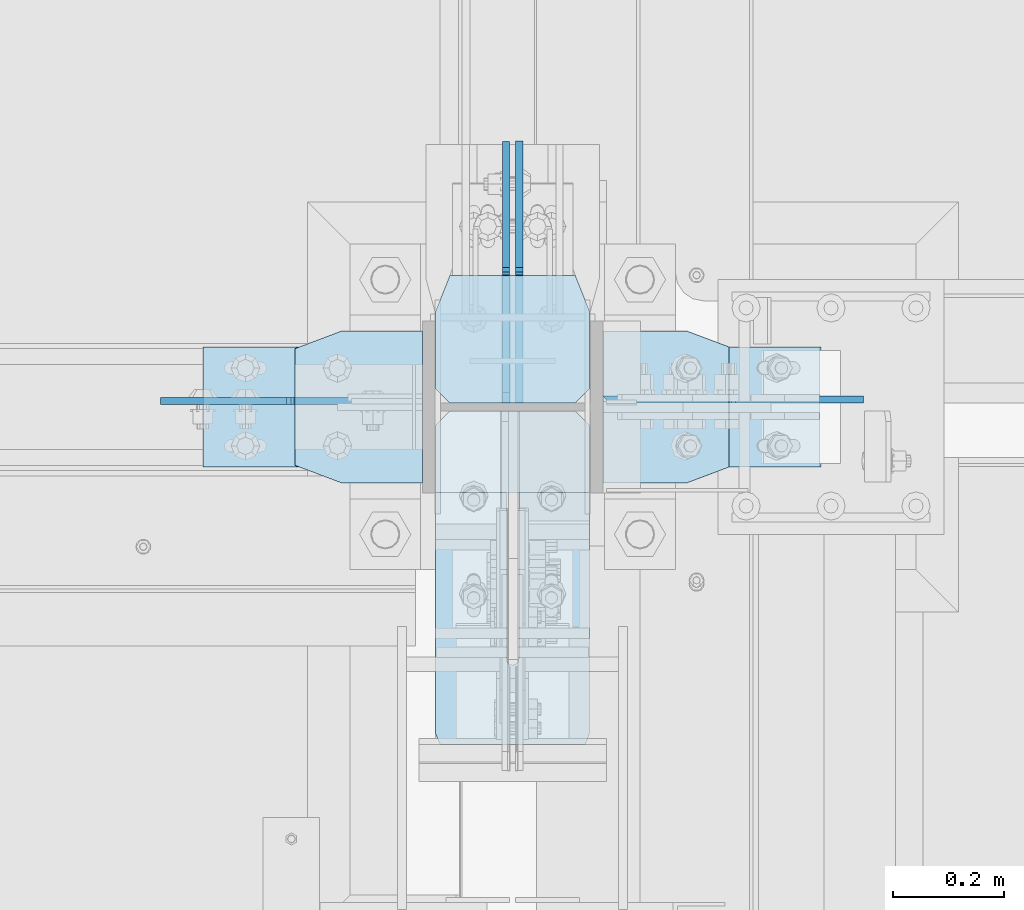
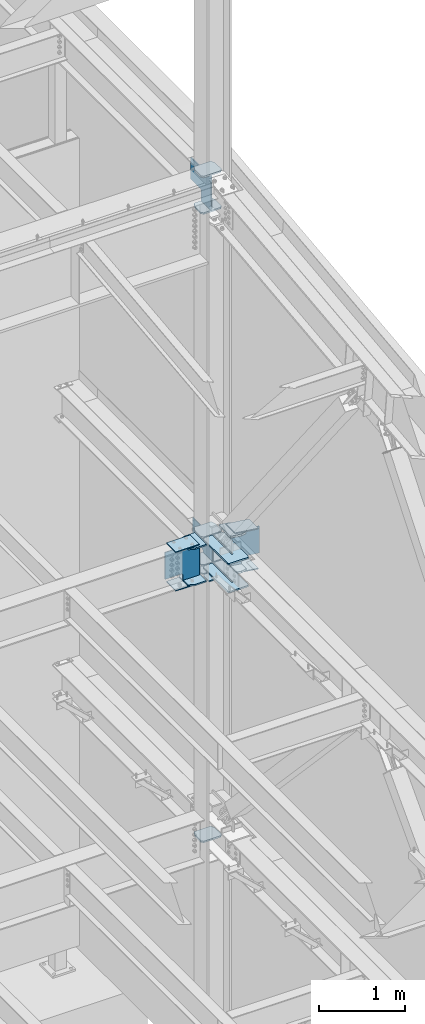
# One storey, part 1091 of 1179: 21 plates, 1 element without a shape of its own.
"""IFC2X3 building model written with IfcOpenShell, lengths in millimetres."""

from ifc_helpers import new_model, si_unit, frame, origin_with_axes, place, context, subcontext, project, spatial, faceted_brep, material, type_object, element, aggregate, save


model = new_model("IFC2X3")

# Units and contexts
model_context = context("Model", 3, precision=1e-05, world=origin_with_axes())
body_context = subcontext(model_context, "Body", "Model", "MODEL_VIEW")
ifc_project = project(units=[si_unit("LENGTHUNIT", "METRE", prefix="MILLI"), si_unit("AREAUNIT", "SQUARE_METRE"), si_unit("VOLUMEUNIT", "CUBIC_METRE"), si_unit("MASSUNIT", "GRAM", prefix="KILO"), si_unit("TIMEUNIT", "SECOND"), si_unit("PLANEANGLEUNIT", "RADIAN"), si_unit("SOLIDANGLEUNIT", "STERADIAN"), si_unit("THERMODYNAMICTEMPERATUREUNIT", "DEGREE_CELSIUS"), si_unit("LUMINOUSINTENSITYUNIT", "LUMEN")], contexts=[model_context])

# Site, building, storey
site_placement = place(None, origin_with_axes())
site = spatial("IfcSite", under=ifc_project, at=site_placement, CompositionType="ELEMENT")
building_placement = place(site_placement, origin_with_axes())
building = spatial("IfcBuilding", under=site, at=building_placement, Name="Undefined", CompositionType="ELEMENT")
storey_placement = place(building_placement, origin_with_axes())
storey = spatial("IfcBuildingStorey", under=building, at=storey_placement, Name="Undefined", CompositionType="ELEMENT", Elevation=0.0)

# Assembly, plates
assembly_placement = place(storey_placement, origin_with_axes())
assembly = element("IfcElementAssembly", 1, at=assembly_placement, inside=storey, Name="COLUMN", AssemblyPlace="NOTDEFINED", PredefinedType="RIGID_FRAME")
ifc_material = material(Name="STEEL/A572-GR.50")
plate_type_1 = type_object("IfcPlateType", PredefinedType="NOTDEFINED")
plate_1_placement = place(assembly_placement, frame((24169.6874938965, 33785.7911790881, 7605.7125), z_axis=(0.0, 1.0, 0.0), x_axis=(1.0, 0.0, 0.0)))
plate_1 = element("IfcPlate", 2, at=plate_1_placement, type_object=plate_type_1, material=ifc_material, Name="PLATE", context=body_context, shape_type="Brep", body=[
    faceted_brep([(127.000006103513, -11.1125000000002, 598.665070911848), (127.000006103513, -11.1125000000002, 153.987500190735), (127.000006103513, 11.1125000000002, 153.987500190735), (127.000006103513, 11.1125000000002, 598.665070911848), (127.845894812999, -11.1125000000002, 149.734930475584), (127.845894812999, 11.1125000000002, 149.734930475584), (130.254782053442, -11.1125000000002, 146.129775949928), (130.254782053442, 11.1125000000002, 146.129775949928), (133.859936579101, -11.1125000000002, 143.720888709489), (133.859936579101, 11.1125000000002, 143.720888709489), (138.112505912784, -11.1125000000002, 142.875), (138.112505912784, 11.1125000000002, 142.875), (142.365075627931, -11.1125000000002, 143.720888709489), (142.365075627931, 11.1125000000002, 143.720888709489), (145.970230153591, -11.1125000000002, 146.129775949928), (145.970230153591, 11.1125000000002, 146.129775949928), (148.379117394034, -11.1125000000002, 149.734930475584), (148.379117394034, 11.1125000000002, 149.734930475584), (149.225006103519, -11.1125000000002, 153.987500190735), (149.225006103519, 11.1125000000002, 153.987500190735), (149.225006103519, -11.1125000000002, 598.665070911848), (149.225006103519, 11.1125000000002, 598.665070911848), (0.0, -11.1125000000002, 573.265071293317), (25.3999996185303, -11.1125000000002, 598.665070911848), (25.3999996185303, 11.1125000000002, 598.665070911848), (0.0, 11.1125000000002, 573.265071293317), (0.0, -11.1125000000002, 19.0499992370605), (0.0, 11.1125000000002, 19.0499992370605), (7.9375, -11.1125000000002, 0.0), (7.9375, 11.1125000000002, 0.0), (268.287506103516, -11.1125000000002, 0.0), (268.287506103516, 11.1125000000002, 0.0), (276.225006103516, -11.1125000000002, 19.0499992370605), (276.225006103516, 11.1125000000002, 19.0499992370605), (276.225006103516, -11.1125000000002, 573.265071293317), (276.225006103516, 11.1125000000002, 573.265071293317), (250.825006484985, -11.1125000000002, 598.665070911848), (250.825006484985, 11.1125000000002, 598.665070911848)], [[[0, 1, 2, 3]], [[4, 5, 2, 1]], [[6, 7, 5, 4]], [[8, 9, 7, 6]], [[10, 11, 9, 8]], [[12, 13, 11, 10]], [[14, 15, 13, 12]], [[16, 17, 15, 14]], [[18, 19, 17, 16]], [[20, 21, 19, 18]], [[22, 23, 24, 25]], [[26, 22, 25, 27]], [[28, 26, 27, 29]], [[30, 28, 29, 31]], [[32, 30, 31, 33]], [[34, 32, 33, 35]], [[36, 34, 35, 37]], [[16, 14, 12, 10, 8, 6, 4, 1, 0, 23, 22, 26, 28, 30, 32, 34, 36, 20, 18]], [[24, 23, 0, 3]], [[37, 35, 33, 31, 29, 27, 25, 24, 3, 2, 5, 7, 9, 11, 13, 15, 17, 19, 21]], [[36, 37, 21, 20]]]),
])
plate_2_placement = place(assembly_placement, frame((24169.6874938965, 33785.7911790881, 8002.5875), z_axis=(0.0, 1.0, 0.0), x_axis=(1.0, 0.0, 0.0)))
plate_2 = element("IfcPlate", 3, at=plate_2_placement, type_object=plate_type_1, material=ifc_material, Name="PLATE", context=body_context, shape_type="Brep", body=[
    faceted_brep([(127.000006103513, -11.1125000000002, 598.665070911848), (127.000006103513, -11.1125000000002, 153.987500190735), (127.000006103513, 11.1125000000002, 153.987500190735), (127.000006103513, 11.1125000000002, 598.665070911848), (127.845894812999, -11.1125000000002, 149.734930475584), (127.845894812999, 11.1125000000002, 149.734930475584), (130.254782053442, -11.1125000000002, 146.129775949928), (130.254782053442, 11.1125000000002, 146.129775949928), (133.859936579101, -11.1125000000002, 143.720888709489), (133.859936579101, 11.1125000000002, 143.720888709489), (138.112505912784, -11.1125000000002, 142.875), (138.112505912784, 11.1125000000002, 142.875), (142.365075627931, -11.1125000000002, 143.720888709489), (142.365075627931, 11.1125000000002, 143.720888709489), (145.970230153591, -11.1125000000002, 146.129775949928), (145.970230153591, 11.1125000000002, 146.129775949928), (148.379117394034, -11.1125000000002, 149.734930475584), (148.379117394034, 11.1125000000002, 149.734930475584), (149.225006103519, -11.1125000000002, 153.987500190735), (149.225006103519, 11.1125000000002, 153.987500190735), (149.225006103519, -11.1125000000002, 598.665070911848), (149.225006103519, 11.1125000000002, 598.665070911848), (0.0, -11.1125000000002, 573.265071293317), (25.3999996185303, -11.1125000000002, 598.665070911848), (25.3999996185303, 11.1125000000002, 598.665070911848), (0.0, 11.1125000000002, 573.265071293317), (0.0, -11.1125000000002, 19.0499992370605), (0.0, 11.1125000000002, 19.0499992370605), (7.9375, -11.1125000000002, 0.0), (7.9375, 11.1125000000002, 0.0), (268.287506103516, -11.1125000000002, 0.0), (268.287506103516, 11.1125000000002, 0.0), (276.225006103516, -11.1125000000002, 19.0499992370605), (276.225006103516, 11.1125000000002, 19.0499992370605), (276.225006103516, -11.1125000000002, 573.265071293317), (276.225006103516, 11.1125000000002, 573.265071293317), (250.825006484985, -11.1125000000002, 598.665070911848), (250.825006484985, 11.1125000000002, 598.665070911848)], [[[0, 1, 2, 3]], [[4, 5, 2, 1]], [[6, 7, 5, 4]], [[8, 9, 7, 6]], [[10, 11, 9, 8]], [[12, 13, 11, 10]], [[14, 15, 13, 12]], [[16, 17, 15, 14]], [[18, 19, 17, 16]], [[20, 21, 19, 18]], [[22, 23, 24, 25]], [[26, 22, 25, 27]], [[28, 26, 27, 29]], [[30, 28, 29, 31]], [[32, 30, 31, 33]], [[34, 32, 33, 35]], [[36, 34, 35, 37]], [[16, 14, 12, 10, 8, 6, 4, 1, 0, 23, 22, 26, 28, 30, 32, 34, 36, 20, 18]], [[24, 23, 0, 3]], [[37, 35, 33, 31, 29, 27, 25, 24, 3, 2, 5, 7, 9, 11, 13, 15, 17, 19, 21]], [[36, 37, 21, 20]]]),
])
plate_type_2 = type_object("IfcPlateType", PredefinedType="NOTDEFINED")
plate_3_placement = place(assembly_placement, frame((23917.2752770017, 34528.125, 7489.82500080334), z_axis=(0.0, -1.0, 0.0), x_axis=(1.0, 0.0, 0.0)))
plate_3 = element("IfcPlate", 4, at=plate_3_placement, type_object=plate_type_2, material=ifc_material, Name="PLATE", context=body_context, shape_type="Brep", body=[
    faceted_brep([(0.0, -9.52499999999964, 31.75), (-1.45519152283669e-11, -9.52499999999964, 241.299987792969), (1.81898940354586e-11, 9.52499999999964, 241.299987792969), (0.0, 9.52499999999964, 31.75), (84.1374969482276, -9.52499999999691, 273.049987792969), (84.1374969482604, 9.52500000000327, 273.049987792969), (228.599999999984, -9.52499999999054, 273.049987792969), (228.600000000017, 9.52500000000964, 273.049987792969), (228.599999999984, -9.52499999999054, 0.0), (228.600000000017, 9.52500000000964, 0.0), (84.1374969482276, -9.52499999999691, 0.0), (84.1374969482604, 9.52500000000327, 0.0)], [[[0, 1, 2, 3]], [[1, 4, 5, 2]], [[4, 6, 7, 5]], [[6, 8, 9, 7]], [[8, 10, 11, 9]], [[10, 0, 3, 11]], [[5, 7, 9, 11, 3, 2]], [[10, 8, 6, 4, 1, 0]]]),
])
plate_4_placement = place(assembly_placement, frame((23917.2752770017, 34528.125, 8004.17499919666), z_axis=(0.0, -1.0, 0.0), x_axis=(1.0, 0.0, 0.0)))
plate_4 = element("IfcPlate", 5, at=plate_4_placement, type_object=plate_type_2, material=ifc_material, Name="PLATE", context=body_context, shape_type="Brep", body=[
    faceted_brep([(0.0, -9.52499999999964, 31.75), (-1.45519152283669e-11, -9.52499999999964, 241.299987792969), (1.81898940354586e-11, 9.52499999999964, 241.299987792969), (0.0, 9.52499999999964, 31.75), (84.1374969482276, -9.52499999999691, 273.049987792969), (84.1374969482604, 9.52500000000327, 273.049987792969), (228.599999999984, -9.52499999999054, 273.049987792969), (228.600000000017, 9.52500000000964, 273.049987792969), (228.599999999984, -9.52499999999054, 0.0), (228.600000000017, 9.52500000000964, 0.0), (84.1374969482276, -9.52499999999691, 0.0), (84.1374969482604, 9.52500000000327, 0.0)], [[[0, 1, 2, 3]], [[1, 4, 5, 2]], [[4, 6, 7, 5]], [[6, 8, 9, 7]], [[8, 10, 11, 9]], [[10, 0, 3, 11]], [[5, 7, 9, 11, 3, 2]], [[10, 8, 6, 4, 1, 0]]]),
])
plate_type_3 = type_object("IfcPlateType", PredefinedType="NOTDEFINED")
plate_5_placement = place(assembly_placement, frame((24445.9125, 34627.34375, 12590.4625), z_axis=(-1.0, 0.0, 0.0), x_axis=(0.0, -1.0, 0.0)))
plate_5 = element("IfcPlate", 6, at=plate_5_placement, type_object=plate_type_3, material=ifc_material, Name="PLATE", context=body_context, shape_type="Brep", body=[
    faceted_brep([(0.0, -11.1125000000002, 25.3999996185303), (0.0, -11.1124999999993, 250.825000381468), (0.0, 11.1124999999993, 250.825000381468), (0.0, 11.1125000000002, 25.3999996185303), (63.5, -11.1124999999993, 276.224999999999), (63.5, 11.1124999999993, 276.224999999999), (203.200000381468, -11.1124999999993, 276.224999999999), (203.200000381468, 11.1124999999993, 276.224999999999), (228.599999999999, -11.1125000000002, 250.824999618533), (228.599999999999, 11.1125000000002, 250.824999618533), (228.599999999999, -11.1124999999993, 25.3999996185303), (228.599999999999, 11.1124999999993, 25.3999996185303), (203.200000381468, -11.1124999999993, 0.0), (203.200000381468, 11.1124999999993, 0.0), (63.5, -11.1125000000002, 0.0), (63.5, 11.1125000000002, 0.0)], [[[0, 1, 2, 3]], [[1, 4, 5, 2]], [[4, 6, 7, 5]], [[6, 8, 9, 7]], [[8, 10, 11, 9]], [[10, 12, 13, 11]], [[12, 14, 15, 13]], [[14, 0, 3, 15]], [[5, 7, 9, 11, 13, 15, 3, 2]], [[14, 12, 10, 8, 6, 4, 1, 0]]]),
])
plate_6_placement = place(assembly_placement, frame((24445.9125, 34627.34375, 13107.9875), z_axis=(-1.0, 0.0, 0.0), x_axis=(0.0, -1.0, 0.0)))
plate_6 = element("IfcPlate", 7, at=plate_6_placement, type_object=plate_type_3, material=ifc_material, Name="PLATE", context=body_context, shape_type="Brep", body=[
    faceted_brep([(0.0, -11.1125000000002, 25.3999996185303), (0.0, -11.1124999999993, 250.825000381468), (0.0, 11.1124999999993, 250.825000381468), (0.0, 11.1125000000002, 25.3999996185303), (63.5, -11.1124999999993, 276.224999999999), (63.5, 11.1124999999993, 276.224999999999), (203.200000381468, -11.1124999999993, 276.224999999999), (203.200000381468, 11.1124999999993, 276.224999999999), (228.599999999999, -11.1125000000002, 250.824999618533), (228.599999999999, 11.1125000000002, 250.824999618533), (228.599999999999, -11.1124999999993, 25.3999996185303), (228.599999999999, 11.1124999999993, 25.3999996185303), (203.200000381468, -11.1124999999993, 0.0), (203.200000381468, 11.1124999999993, 0.0), (63.5, -11.1125000000002, 0.0), (63.5, 11.1125000000002, 0.0)], [[[0, 1, 2, 3]], [[1, 4, 5, 2]], [[4, 6, 7, 5]], [[6, 8, 9, 7]], [[8, 10, 11, 9]], [[10, 12, 13, 11]], [[12, 14, 15, 13]], [[14, 0, 3, 15]], [[5, 7, 9, 11, 13, 15, 3, 2]], [[14, 12, 10, 8, 6, 4, 1, 0]]]),
])
plate_7_placement = place(assembly_placement, frame((24445.9125, 34627.34375, 7608.8875), z_axis=(-1.0, 0.0, 0.0), x_axis=(0.0, -1.0, 0.0)))
plate_7 = element("IfcPlate", 8, at=plate_7_placement, type_object=plate_type_3, material=ifc_material, Name="PLATE", context=body_context, shape_type="Brep", body=[
    faceted_brep([(0.0, -11.1124999999993, 250.825000381468), (63.5, -11.1124999999993, 276.224999999999), (63.5, 11.1124999999993, 276.224999999999), (0.0, 11.1124999999993, 250.825000381468), (63.5, -11.1125000000002, 0.0), (0.0, -11.1125000000002, 25.3999996185303), (0.0, 11.1125000000002, 25.3999996185303), (63.5, 11.1125000000002, 0.0), (203.200000381468, -11.1124999999993, 276.224999999999), (203.200000381468, 11.1124999999993, 276.224999999999), (228.599999999999, -11.1125000000002, 250.824999618533), (228.599999999999, 11.1125000000002, 250.824999618533), (228.599999999999, -11.1124999999993, 25.3999996185303), (228.599999999999, 11.1124999999993, 25.3999996185303), (203.200000381468, -11.1124999999993, 0.0), (203.200000381468, 11.1124999999993, 0.0)], [[[0, 1, 2, 3]], [[4, 5, 6, 7]], [[5, 0, 3, 6]], [[1, 8, 9, 2]], [[8, 10, 11, 9]], [[10, 12, 13, 11]], [[12, 14, 15, 13]], [[14, 4, 7, 15]], [[2, 9, 11, 13, 15, 7, 6, 3]], [[4, 14, 12, 10, 8, 1, 0, 5]]]),
])
plate_8_placement = place(assembly_placement, frame((24445.9125, 34627.34375, 8002.5875), z_axis=(-1.0, 0.0, 0.0), x_axis=(0.0, -1.0, 0.0)))
plate_8 = element("IfcPlate", 9, at=plate_8_placement, type_object=plate_type_3, material=ifc_material, Name="PLATE", context=body_context, shape_type="Brep", body=[
    faceted_brep([(0.0, -11.1124999999993, 250.825000381468), (63.5, -11.1124999999993, 276.224999999999), (63.5, 11.1124999999993, 276.224999999999), (0.0, 11.1124999999993, 250.825000381468), (63.5, -11.1125000000002, 0.0), (0.0, -11.1125000000002, 25.3999996185303), (0.0, 11.1125000000002, 25.3999996185303), (63.5, 11.1125000000002, 0.0), (203.200000381468, -11.1124999999993, 276.224999999999), (203.200000381468, 11.1124999999993, 276.224999999999), (228.599999999999, -11.1125000000002, 250.824999618533), (228.599999999999, 11.1125000000002, 250.824999618533), (228.599999999999, -11.1124999999993, 25.3999996185303), (228.599999999999, 11.1124999999993, 25.3999996185303), (203.200000381468, -11.1124999999993, 0.0), (203.200000381468, 11.1124999999993, 0.0)], [[[0, 1, 2, 3]], [[4, 5, 6, 7]], [[5, 0, 3, 6]], [[1, 8, 9, 2]], [[8, 10, 11, 9]], [[10, 12, 13, 11]], [[12, 14, 15, 13]], [[14, 4, 7, 15]], [[2, 9, 11, 13, 15, 7, 6, 3]], [[4, 14, 12, 10, 8, 1, 0, 5]]]),
])
plate_9_placement = place(assembly_placement, frame((24445.9125, 34627.34375, 3694.1125), z_axis=(-1.0, 0.0, 0.0), x_axis=(0.0, -1.0, 0.0)))
plate_9 = element("IfcPlate", 10, at=plate_9_placement, type_object=plate_type_3, material=ifc_material, Name="PLATE", context=body_context, shape_type="Brep", body=[
    faceted_brep([(63.5, -11.1125000000002, 0.0), (0.0, -11.1125000000002, 25.3999996185303), (0.0, 11.1125000000002, 25.3999996185303), (63.5, 11.1125000000002, 0.0), (0.0, -11.1124999999993, 250.825000381468), (63.5, -11.1124999999993, 276.224999999999), (63.5, 11.1124999999993, 276.224999999999), (0.0, 11.1124999999993, 250.825000381468), (203.200000381468, -11.1124999999993, 276.224999999999), (203.200000381468, 11.1124999999993, 276.224999999999), (228.599999999999, -11.1125000000002, 250.824999618533), (228.599999999999, 11.1125000000002, 250.824999618533), (228.599999999999, -11.1124999999993, 25.3999996185303), (228.599999999999, 11.1124999999993, 25.3999996185303), (203.200000381468, -11.1124999999993, 0.0), (203.200000381468, 11.1124999999993, 0.0)], [[[0, 1, 2, 3]], [[4, 5, 6, 7]], [[1, 4, 7, 2]], [[5, 8, 9, 6]], [[8, 10, 11, 9]], [[10, 12, 13, 11]], [[12, 14, 15, 13]], [[14, 0, 3, 15]], [[6, 9, 11, 13, 15, 3, 2, 7]], [[0, 14, 12, 10, 8, 5, 4, 1]]]),
])
plate_type_4 = type_object("IfcPlateType", PredefinedType="NOTDEFINED")
plate_10_placement = place(assembly_placement, frame((24295.89375, 34398.7437499185, 12620.625), z_axis=(0.0, 0.707106781186542, 0.707106781186553), x_axis=(0.0, 0.707106781186553, -0.707106781186542)))
plate_10 = element("IfcPlate", 11, at=plate_10_placement, type_object=plate_type_4, material=ifc_material, Name="PLATE", context=body_context, shape_type="Brep", body=[
    faceted_brep([(0.0, -6.34999999999854, 0.0), (-323.289220358607, -6.35000000000002, 323.289220358594), (-323.289220358607, 6.35000000000002, 323.289220358594), (0.0, 6.34999999999854, 0.0), (-323.289220358678, -6.35000000000002, 350.229988721738), (-323.289220358678, 6.35000000000002, 350.229988721738), (-175.676260369275, -6.34999999999854, 497.842948711121), (-175.676260369275, 6.34999999999854, 497.842948711121), (-173.431196069267, -6.34999999999854, 495.597884411116), (-173.431196069267, 6.34999999999854, 495.597884411116), (-165.190843132961, -6.34999999999854, 490.091856610146), (-165.190843132961, 6.34999999999854, 490.091856610146), (-155.470684096883, -6.34999999999854, 488.158396764957), (-155.470684096883, 6.34999999999854, 488.158396764957), (-145.750525060801, -6.34999999999854, 490.091856610125), (-145.750525060801, 6.34999999999854, 490.091856610125), (-137.510172124514, -6.34999999999854, 495.597884411058), (-137.510172124514, 6.34999999999854, 495.597884411058), (15.1541822026338, -6.34999999999854, 648.2622387382), (15.1541822026338, 6.34999999999854, 648.2622387382), (230.680329108358, -6.34999999999854, 432.736091832448), (230.680329108358, 6.34999999999854, 432.736091832448), (78.015974781214, -6.34999999999854, 280.071737505328), (78.015974781214, 6.34999999999854, 280.071737505328), (72.5099469802699, -6.34999999999854, 271.831384569035), (72.5099469802699, 6.34999999999854, 271.831384569035), (70.5764871351112, -6.34999999999854, 262.111225532957), (70.5764871351112, 6.34999999999854, 262.111225532957), (72.509946980299, -6.34999999999854, 252.391066496879), (72.509946980299, 6.34999999999854, 252.391066496879), (78.015974781254, -6.34999999999854, 244.150713560572), (78.015974781254, 6.34999999999854, 244.150713560572), (174.553728352508, -6.34999999999854, 147.612959989299), (174.553728352508, 6.34999999999854, 147.612959989299), (26.9407683631471, -6.34999999999854, -6.91215973347425e-11), (26.9407683631471, 6.34999999999854, -6.91215973347425e-11)], [[[0, 1, 2, 3]], [[1, 4, 5, 2]], [[4, 6, 7, 5]], [[6, 8, 9, 7]], [[8, 10, 11, 9]], [[10, 12, 13, 11]], [[12, 14, 15, 13]], [[14, 16, 17, 15]], [[16, 18, 19, 17]], [[18, 20, 21, 19]], [[20, 22, 23, 21]], [[22, 24, 25, 23]], [[24, 26, 27, 25]], [[26, 28, 29, 27]], [[28, 30, 31, 29]], [[30, 32, 33, 31]], [[32, 34, 35, 33]], [[34, 0, 3, 35]], [[5, 7, 9, 11, 13, 15, 17, 19, 21, 23, 25, 27, 29, 31, 33, 35, 3, 2]], [[34, 32, 30, 28, 26, 24, 22, 20, 18, 16, 14, 12, 10, 8, 6, 4, 1, 0]]]),
])
plate_11_placement = place(assembly_placement, frame((24145.875, 34402.7125, 7994.65), z_axis=(-1.0, 0.0, 0.0), x_axis=(0.0, 0.0, -1.0)))
plate_11 = element("IfcPlate", 12, at=plate_11_placement, type_object=plate_type_4, material=ifc_material, Name="PLATE", context=body_context, shape_type="Brep", body=[
    faceted_brep([(495.3, 6.34999999999854, 12.7000000000007), (495.3, -6.34999999999854, 0.0), (0.0, -6.34999999999854, 0.0), (0.0, 6.35000000000036, 12.6999999999571), (400.049987793925, -6.34999999999854, 469.900000816429), (400.049987074385, -6.34999999999854, 253.999723479657), (400.049987074385, 6.34999999999854, 253.999723479657), (400.049987793925, 6.34999999999854, 469.900000816429), (401.983446895269, -6.34999999999854, 244.27956441756), (401.983446895269, 6.34999999999854, 244.27956441756), (407.489474690605, -6.34999999999854, 236.03921145252), (407.489474690605, 6.34999999999854, 236.03921145252), (415.729827637304, -6.34999999999854, 230.533183629737), (415.729827637304, 6.34999999999854, 230.533183629737), (425.449986692962, -6.34999999999854, 228.599723776479), (425.449986692962, 6.34999999999854, 228.599723776479), (495.299999196217, -6.34999999999854, 228.599723776602), (495.3, 6.34999999999854, 228.599723776602), (19.0500000066177, -6.34999999999854, 469.900000816731), (19.0500000066177, 6.34999999999854, 469.900000816429), (19.0500000014745, 6.34999999999854, 253.999723394838), (19.0500000014745, -6.34999999999854, 253.999723394838), (17.1165401561248, 6.34999999999854, 244.279564358931), (17.1165401561248, -6.34999999999854, 244.279564358931), (11.610512355127, 6.34999999999854, 236.039211422831), (11.610512355127, -6.34999999999854, 236.039211422831), (3.3701594188924, 6.34999999999854, 230.533183622028), (3.3701594188924, -6.34999999999854, 230.533183622028), (0.0, 6.34999999999854, 229.862817233581), (0.0, -6.34999999999854, 229.862817233581), (0.0, -6.34999999999854, 228.599723776912), (0.0, 6.34999999999854, 228.599723776912)], [[[0, 1, 2, 3]], [[4, 5, 6, 7]], [[8, 9, 6, 5]], [[10, 11, 9, 8]], [[12, 13, 11, 10]], [[14, 15, 13, 12]], [[16, 17, 15, 14]], [[18, 19, 20, 21]], [[21, 20, 22, 23]], [[23, 22, 24, 25]], [[25, 24, 26, 27]], [[27, 26, 28, 29]], [[30, 29, 28, 31, 3, 2]], [[23, 25, 27, 29, 30, 2, 1, 16, 14, 12, 10, 8, 5, 4, 18, 21]], [[4, 7, 19, 18]], [[31, 28, 26, 24, 22, 20, 19, 7, 6, 9, 11, 13, 15, 17, 0, 3]], [[17, 16, 1, 0]]]),
])
plate_type_5 = type_object("IfcPlateType", PredefinedType="NOTDEFINED")
plate_12_placement = place(assembly_placement, frame((23752.1750017409, 34499.5499969482, 7473.95000087879), z_axis=(0.0, -1.0, 0.0), x_axis=(1.0, 0.0, 0.0)))
plate_12 = element("IfcPlate", 13, at=plate_12_placement, type_object=plate_type_5, material=ifc_material, Name="PLATE", context=body_context, shape_type="Brep", body=[
    faceted_brep([(0.0, -6.34999999999854, 0.0), (0.0, -6.350000000004, 215.899993896484), (0.0, 6.35000000000582, 215.899993896484), (0.0, 6.34999999999854, 0.0), (317.499999999996, -6.35000000014134, 215.899993896484), (317.5, 6.34999999985939, 215.899993896484), (317.499999999996, -6.35000000014134, 0.0), (317.5, 6.34999999985939, 0.0)], [[[0, 1, 2, 3]], [[1, 4, 5, 2]], [[4, 6, 7, 5]], [[6, 0, 3, 7]], [[5, 7, 3, 2]], [[6, 4, 1, 0]]]),
])
plate_13_placement = place(assembly_placement, frame((23752.1750017409, 34499.5499969482, 8020.04999912121), z_axis=(0.0, -1.0, 0.0), x_axis=(1.0, 0.0, 0.0)))
plate_13 = element("IfcPlate", 14, at=plate_13_placement, type_object=plate_type_5, material=ifc_material, Name="PLATE", context=body_context, shape_type="Brep", body=[
    faceted_brep([(0.0, -6.34999999999854, 0.0), (0.0, -6.350000000004, 215.899993896484), (0.0, 6.35000000000582, 215.899993896484), (0.0, 6.34999999999854, 0.0), (317.499999999996, -6.35000000014134, 215.899993896484), (317.5, 6.34999999985939, 215.899993896484), (317.499999999996, -6.35000000014134, 0.0), (317.5, 6.34999999985939, 0.0)], [[[0, 1, 2, 3]], [[1, 4, 5, 2]], [[4, 6, 7, 5]], [[6, 0, 3, 7]], [[5, 7, 3, 2]], [[6, 4, 1, 0]]]),
])
plate_14_placement = place(assembly_placement, frame((24859.0345724513, 34283.6500030518, 7401.53692644335), z_axis=(0.0, 1.0, 0.0), x_axis=(-0.99100656978554, 0.0, 0.133813222971043)))
plate_14 = element("IfcPlate", 15, at=plate_14_placement, type_object=plate_type_5, material=ifc_material, Name="PLATE", context=body_context, shape_type="Brep", body=[
    faceted_brep([(0.0, -6.34999999999854, 0.0), (0.0, -6.350000000004, 215.899993896484), (0.0, 6.35000000000582, 215.899993896484), (0.0, 6.34999999999854, 0.0), (317.499999999996, -6.35000000014134, 215.899993896484), (317.5, 6.34999999985939, 215.899993896484), (317.499999999996, -6.35000000014134, 0.0), (317.5, 6.34999999985939, 0.0)], [[[0, 1, 2, 3]], [[1, 4, 5, 2]], [[4, 6, 7, 5]], [[6, 0, 3, 7]], [[5, 7, 3, 2]], [[6, 4, 1, 0]]]),
])
plate_15_placement = place(assembly_placement, frame((24860.7340003896, 34283.6500030518, 7968.38240584238), z_axis=(0.0, 1.0, 0.0), x_axis=(-0.99100656978554, 0.0, 0.133813222971043)))
plate_15 = element("IfcPlate", 16, at=plate_15_placement, type_object=plate_type_5, material=ifc_material, Name="PLATE", context=body_context, shape_type="Brep", body=[
    faceted_brep([(0.0, -6.34999999999854, 0.0), (0.0, -6.350000000004, 215.899993896484), (0.0, 6.35000000000582, 215.899993896484), (0.0, 6.34999999999854, 0.0), (317.499999999996, -6.35000000014134, 215.899993896484), (317.5, 6.34999999985939, 215.899993896484), (317.499999999996, -6.35000000014134, 0.0), (317.5, 6.34999999985939, 0.0)], [[[0, 1, 2, 3]], [[1, 4, 5, 2]], [[4, 6, 7, 5]], [[6, 0, 3, 7]], [[5, 7, 3, 2]], [[6, 4, 1, 0]]]),
])
plate_type_6 = type_object("IfcPlateType", PredefinedType="NOTDEFINED")
plate_16_placement = place(assembly_placement, frame((24698.2266162988, 34255.075, 7444.07522286291), z_axis=(0.0, 1.0, 0.0), x_axis=(-0.99100656978554, 0.0, 0.133813222971043)))
plate_16 = element("IfcPlate", 17, at=plate_16_placement, type_object=plate_type_6, material=ifc_material, Name="PLATE", context=body_context, shape_type="Brep", body=[
    faceted_brep([(80.9625015258825, 14.2875000000258, 0.0), (80.9625015259153, -14.287499999984, 0.0), (0.0, -14.2875000000004, 30.1625003814697), (3.85841324523426, 14.287500000004, 28.7250523186231), (0.0, -14.2874999999999, 242.887505722043), (3.85841324523426, 14.287500000004, 244.324935474346), (80.9625015259153, -14.287499999984, 273.049987792969), (80.9625015258825, 14.2875000000258, 273.049987792969), (232.504463918263, 14.2875000000677, 273.049987792969), (232.504463918263, 14.2875000000677, 0.0), (228.646069701834, -14.287499999944, 0.0), (228.646069701834, -14.287499999944, 273.049987792969)], [[[0, 1, 2, 3]], [[2, 4, 5, 3]], [[6, 7, 5, 4]], [[0, 3, 5, 7, 8, 9]], [[1, 0, 9, 10]], [[6, 4, 2, 1, 10, 11]], [[7, 6, 11, 8]], [[10, 9, 8, 11]]]),
])
plate_17_placement = place(assembly_placement, frame((24698.1539305541, 34255.075, 7969.51041486799), z_axis=(0.0, 1.0, 0.0), x_axis=(-0.99100656978554, 0.0, 0.133813222971043)))
plate_17 = element("IfcPlate", 18, at=plate_17_placement, type_object=plate_type_6, material=ifc_material, Name="PLATE", context=body_context, shape_type="Brep", body=[
    faceted_brep([(80.9625015258825, 14.2875000000258, 0.0), (80.9625015259153, -14.287499999984, 0.0), (0.0, -14.2875000000004, 30.1625003814697), (3.83114020848734, 14.2875000000095, 28.7352128616549), (0.0, -14.2874999999999, 242.887505722043), (3.83114020848734, 14.2875000000095, 244.314774931314), (80.9625015259153, -14.287499999984, 273.049987792969), (80.9625015258825, 14.2875000000258, 273.049987792969), (232.431138771321, 14.2875000000713, 273.049987792969), (232.431138771321, 14.2875000000713, 0.0), (228.5727198233, -14.2874999999403, 0.0), (228.5727198233, -14.2874999999403, 273.049987792969)], [[[0, 1, 2, 3]], [[2, 4, 5, 3]], [[6, 7, 5, 4]], [[0, 3, 5, 7, 8, 9]], [[1, 0, 9, 10]], [[6, 4, 2, 1, 10, 11]], [[7, 6, 11, 8]], [[10, 9, 8, 11]]]),
])
plate_type_7 = type_object("IfcPlateType", PredefinedType="NOTDEFINED")
plate_18_placement = place(assembly_placement, frame((24445.9125, 34384.45625, 7488.2375), z_axis=(-1.0, 0.0, 0.0), x_axis=(0.0, -1.0, 0.0)))
plate_18 = element("IfcPlate", 19, at=plate_18_placement, type_object=plate_type_7, material=ifc_material, Name="PLATE", context=body_context, shape_type="Brep", body=[
    faceted_brep([(0.0, -7.9375, 25.3999996185303), (0.0, -7.9375, 250.824987411499), (0.0, 7.9375, 250.824987411499), (-2.63229335373174e-12, 7.9375, 25.3999996185303), (25.3999996185303, -7.9375, 276.224999999999), (25.3999996185303, 7.9375, 276.224999999999), (146.049999999996, -7.9375, 276.224999999999), (146.049999999996, 7.9375, 276.224999999999), (146.050003051758, -7.9375, 0.0), (146.050003051758, 7.9375, 0.0), (25.4000000002561, -7.9375, 0.0), (25.4000000002561, 7.9375, 0.0)], [[[0, 1, 2, 3]], [[1, 4, 5, 2]], [[4, 6, 7, 5]], [[6, 8, 9, 7]], [[8, 10, 11, 9]], [[10, 0, 3, 11]], [[5, 7, 9, 11, 3, 2]], [[10, 8, 6, 4, 1, 0]]]),
])
plate_19_placement = place(assembly_placement, frame((24445.9125, 34544.79375, 7488.2375), z_axis=(-1.0, 0.0, 0.0), x_axis=(0.0, -1.0, 0.0)))
plate_19 = element("IfcPlate", 20, at=plate_19_placement, type_object=plate_type_7, material=ifc_material, Name="PLATE", context=body_context, shape_type="Brep", body=[
    faceted_brep([(0.0, -7.9375, 0.0), (0.0, -7.9375, 276.225006103516), (0.0, 7.9375, 276.225006103516), (0.0, 7.9375, 0.0), (120.650000381465, -7.9375, 276.224999999999), (120.650000381465, 7.9375, 276.224999999999), (146.050003051758, -7.9375, 250.824987411499), (146.050003051758, 7.9375, 250.824987411499), (146.049999999996, -7.9375, 25.3999996185303), (146.049999999996, 7.9375, 25.3999996185303), (120.650000381465, -7.9375, 0.0), (120.650000381465, 7.9375, 0.0)], [[[0, 1, 2, 3]], [[1, 4, 5, 2]], [[4, 6, 7, 5]], [[6, 8, 9, 7]], [[8, 10, 11, 9]], [[10, 0, 3, 11]], [[5, 7, 9, 11, 3, 2]], [[10, 8, 6, 4, 1, 0]]]),
])
plate_type_8 = type_object("IfcPlateType", PredefinedType="NOTDEFINED")
plate_20_placement = place(assembly_placement, frame((24937.4548854329, 34405.09375, 7922.7810233903), z_axis=(-0.133813222971046, 0.0, -0.991006569785539), x_axis=(-0.99100656978554, 0.0, 0.133813222971043)))
plate_20 = element("IfcPlate", 21, at=plate_20_placement, type_object=plate_type_8, material=ifc_material, Name="PLATE", context=body_context, shape_type="Brep", body=[
    faceted_brep([(459.159415951235, -6.34999999999854, -0.000894369919478777), (471.9745483404, 6.34999999999854, 1.54614099301398e-10), (405.524078369628, 6.34999999999854, 492.12500000018), (392.708825215796, -6.34999999999854, 492.12500000018), (161.198477304897, -6.34999999999854, 393.048755782353), (161.198477304897, 6.34999999999854, 393.048755782353), (-53.0724195891562, 6.34999999999854, 393.048739880704), (-53.0724195891562, -6.34999999999854, 393.048739880704), (169.692620290516, -6.34999999999854, 394.51113900577), (169.692620290516, 6.34999999999854, 394.51113900577), (177.208677497092, -6.34999999999854, 398.729896384402), (177.208677497092, 6.34999999999854, 398.729896384402), (182.88118824167, -6.34999999999854, 405.219245473845), (182.88118824167, 6.34999999999854, 405.219245473845), (186.056972953109, -6.34999999999854, 413.231949213437), (186.056972953109, 6.34999999999854, 413.231949213437), (186.37034564342, -6.34999999999854, 421.845358951092), (186.37034564342, 6.34999999999854, 421.845358951092), (176.887058408014, -6.34999999999854, 492.125000000156), (176.887058408014, 6.34999999999854, 492.125000000156), (243.372571850105, -6.34999999999854, -0.0159541671655461), (243.372571850101, 6.34999999999854, 7.82165443524718e-11), (237.861119982666, -6.34999999999854, 8.2269752358352), (237.861119982666, 6.34999999999854, 8.2269752358352), (229.61363037601, -6.34999999999854, 13.7316007469908), (229.61363037601, 6.34999999999854, 13.7316007469908), (219.887015406672, -6.34999999999854, 15.6590208019315), (219.887015406672, 6.34999999999854, 15.6590208019315), (-2.0895845120067, -6.34999999999854, 15.4752424267954), (-2.0895845120067, 6.34999999999854, 15.4752424267954)], [[[0, 1, 2, 3]], [[4, 5, 6, 7]], [[8, 9, 5, 4]], [[10, 11, 9, 8]], [[12, 13, 11, 10]], [[14, 15, 13, 12]], [[16, 17, 15, 14]], [[18, 19, 17, 16]], [[20, 21, 1, 0]], [[20, 22, 23, 21]], [[24, 25, 23, 22]], [[26, 27, 25, 24]], [[28, 29, 27, 26]], [[29, 28, 7, 6]], [[2, 1, 21, 23, 25, 27, 29, 6, 5, 9, 11, 13, 15, 17, 19]], [[19, 18, 3, 2]], [[18, 16, 14, 12, 10, 8, 4, 7, 28, 26, 24, 22, 20, 0, 3]]]),
])
plate_type_9 = type_object("IfcPlateType", PredefinedType="NOTDEFINED")
plate_21_placement = place(assembly_placement, frame((24319.7062500954, 34398.7437499907, 7991.47500339458), z_axis=(0.0, 1.0, 0.0), x_axis=(0.0, 0.0, -1.0)))
plate_21 = element("IfcPlate", 22, at=plate_21_placement, type_object=plate_type_9, material=ifc_material, Name="PLATE", context=body_context, shape_type="Brep", body=[
    faceted_brep([(0.0, -6.34999999999854, 0.0), (3.39457801601384e-06, -6.34999999999854, 227.806248864537), (3.39457801601384e-06, 6.34999999999854, 227.806248864537), (0.0, 6.34999999999854, 0.0), (3.17500377604665, -6.34999999999854, 227.806248864537), (3.17500377604665, 6.34999999999854, 227.806248864537), (12.8951628121376, -6.34999999999854, 229.739708709712), (12.8951628121376, 6.34999999999854, 229.739708709712), (21.135515748445, -6.34999999999854, 235.245736510667), (21.135515748445, 6.34999999999854, 235.245736510667), (26.6415435494009, -6.34999999999854, 243.486089446975), (26.6415435494009, 6.34999999999854, 243.486089446975), (28.5750033945769, -6.34999999999854, 253.206248483068), (28.5750033945769, 6.34999999999854, 253.206248483068), (28.5750033945769, -6.34999999999854, 470.693753737585), (28.5750033945769, 6.34999999999854, 470.693753737585), (333.375003394577, -6.34999999999854, 470.693753737585), (333.375003394577, 6.34999999999854, 470.693753737585), (333.375003394577, -6.34999999999854, 253.206248483068), (333.375003394577, 6.34999999999854, 253.206248483068), (335.308463239753, -6.34999999999854, 243.486089446975), (335.308463239753, 6.34999999999854, 243.486089446975), (340.814491040709, -6.34999999999854, 235.245736510667), (340.814491040709, 6.34999999999854, 235.245736510667), (349.054843977016, -6.34999999999854, 229.739708709712), (349.054843977016, 6.34999999999854, 229.739708709712), (358.775003013107, -6.34999999999854, 227.806248864537), (358.775003013107, 6.34999999999854, 227.806248864537), (371.475003394577, -6.34999999999854, 227.806248864537), (371.475003394577, 6.34999999999854, 227.806248864537), (371.474999999999, -6.34999999999854, 0.0), (371.474999999999, 6.34999999999854, 0.0)], [[[0, 1, 2, 3]], [[1, 4, 5, 2]], [[4, 6, 7, 5]], [[6, 8, 9, 7]], [[8, 10, 11, 9]], [[10, 12, 13, 11]], [[12, 14, 15, 13]], [[14, 16, 17, 15]], [[16, 18, 19, 17]], [[18, 20, 21, 19]], [[20, 22, 23, 21]], [[22, 24, 25, 23]], [[24, 26, 27, 25]], [[26, 28, 29, 27]], [[28, 30, 31, 29]], [[30, 0, 3, 31]], [[5, 7, 9, 11, 13, 15, 17, 19, 21, 23, 25, 27, 29, 31, 3, 2]], [[30, 28, 26, 24, 22, 20, 18, 16, 14, 12, 10, 8, 6, 4, 1, 0]]]),
])
aggregate(assembly, [plate_1, plate_2, plate_12, plate_3, plate_13, plate_4, plate_14, plate_16, plate_20, plate_15, plate_17, plate_5, plate_6, plate_10, plate_18, plate_19, plate_11, plate_7, plate_8, plate_21, plate_9])

save(model, "model.ifc")
